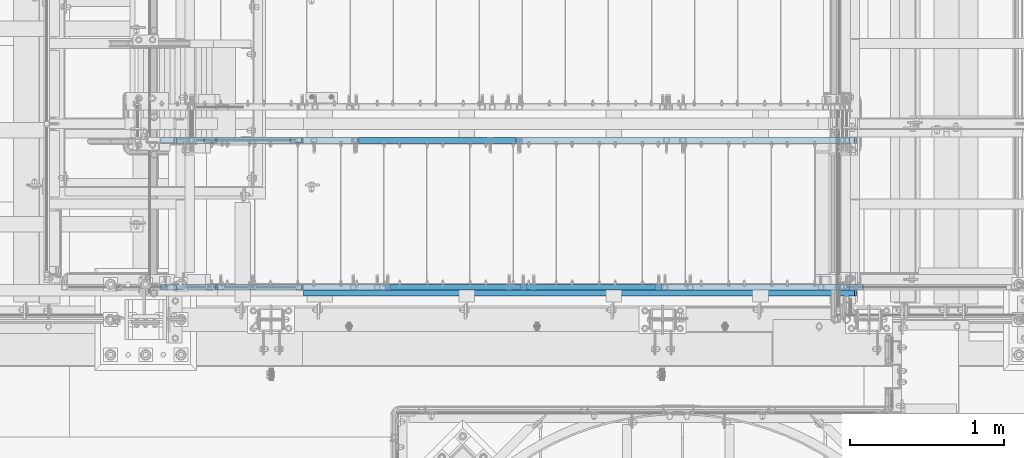
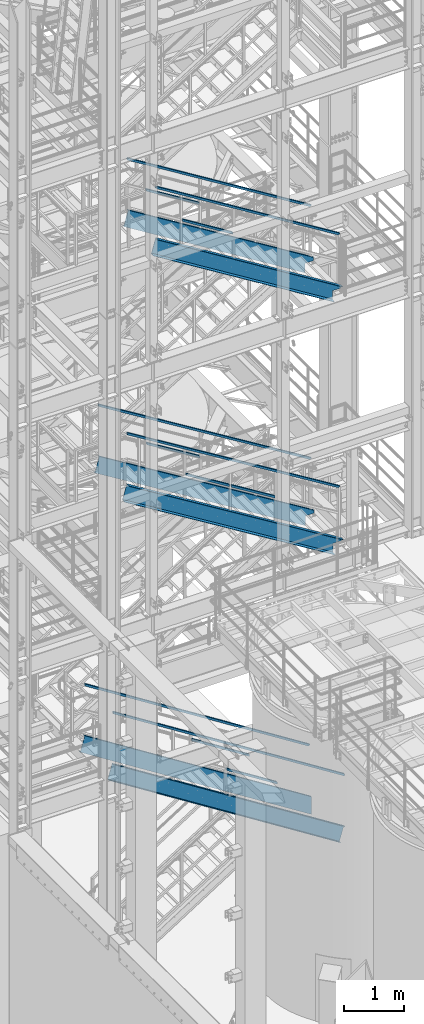
# One storey, part 947 of 1876: 19 members, 9 elements without a shape of their own.
"""IFC2X3 building model written with IfcOpenShell, lengths in millimetres."""

import ifcopenshell
import ifcopenshell.guid

model = None  # the IFC model being written
_history = None  # IfcOwnerHistory: only IFC2X3 demands one
_inside = {}  # id of a spatial element -> (the spatial element, [elements in it])
_under = {}  # id of a project, library or spatial element -> (it, [spatial elements below it])
_declared = {}  # id of a project -> (the project, [libraries it declares])
_typed = {}  # id of a type object -> (the type object, [elements of that type])
_made_of = {}  # id of a material, layer set ... -> (it, [elements and type objects made of it])


def new_model(schema):
    """Start an empty IFC model of exactly this schema.

    Asked for "IFC4X3", IfcOpenShell would pick the latest addendum, in which some entities
    have other attributes; the version numbers below select the first issue.
    IFC2X3 requires an IfcOwnerHistory on every rooted entity: one is made here for all.
    """
    global model, _history
    if schema == "IFC4X3":
        model = ifcopenshell.file(schema_version=(4, 3, 0, 0))
    else:
        model = ifcopenshell.file(schema=schema)
    _inside.clear()
    _under.clear()
    _declared.clear()
    _typed.clear()
    _made_of.clear()
    _history = None
    if model.schema == "IFC2X3":
        org = make("IfcOrganization", Name="unknown")
        user = make(
            "IfcPersonAndOrganization",
            ThePerson=make("IfcPerson", FamilyName="unknown"),
            TheOrganization=org,
        )
        app = make(
            "IfcApplication",
            ApplicationDeveloper=org,
            Version="unknown",
            ApplicationFullName="unknown",
            ApplicationIdentifier="unknown",
        )
        _history = make(
            "IfcOwnerHistory",
            OwningUser=user,
            OwningApplication=app,
            ChangeAction="ADDED",
            CreationDate=0,
        )
    return model


def make(cls, **values):
    """One entity of the class cls with the attributes given. An attribute that is None is left unset."""
    return model.create_entity(
        cls, **{name: value for name, value in values.items() if value is not None}
    )


def rooted(cls, **values):
    """An entity with a GlobalId (a new one), such as an element, a storey or a relation."""
    return make(cls, GlobalId=ifcopenshell.guid.new(), OwnerHistory=_history, **values)


def si_unit(unit_type, name, prefix=None):
    """IfcSIUnit, for example si_unit("LENGTHUNIT", "METRE", prefix="MILLI")."""
    return make("IfcSIUnit", UnitType=unit_type, Prefix=prefix, Name=name)


def assignment(units):
    """IfcUnitAssignment: the units of a project."""
    return None if units is None else make("IfcUnitAssignment", Units=units)


def point(xyz):
    """IfcCartesianPoint."""
    return None if xyz is None else make("IfcCartesianPoint", Coordinates=xyz)


def direction(xyz):
    """IfcDirection."""
    return None if xyz is None else make("IfcDirection", DirectionRatios=xyz)


def frame(location, z_axis=None, x_axis=None):
    """IfcAxis2Placement3D, a coordinate frame: its origin and axes. An axis left out is left unset."""
    return make(
        "IfcAxis2Placement3D",
        Location=point(location),
        Axis=direction(z_axis),
        RefDirection=direction(x_axis),
    )


def origin_with_axes():
    """The frame at (0, 0, 0) with the z axis (0, 0, 1) and the x axis (1, 0, 0) written out."""
    return frame((0.0, 0.0, 0.0), z_axis=(0.0, 0.0, 1.0), x_axis=(1.0, 0.0, 0.0))


def place(relative_to, where):
    """IfcLocalPlacement: puts the frame where relative to a parent placement (None: the world)."""
    return make(
        "IfcLocalPlacement", PlacementRelTo=relative_to, RelativePlacement=where
    )


def context(
    kind, dimensions, precision=None, world=None, true_north=None, identifier=None
):
    """IfcGeometricRepresentationContext, for example the 3D "Model" context."""
    return make(
        "IfcGeometricRepresentationContext",
        ContextIdentifier=identifier,
        ContextType=kind,
        CoordinateSpaceDimension=dimensions,
        Precision=precision,
        WorldCoordinateSystem=world,
        TrueNorth=true_north,
    )


def subcontext(parent, identifier, kind, view, scale=None):
    """IfcGeometricRepresentationSubContext, for example "Body" below "Model"."""
    return make(
        "IfcGeometricRepresentationSubContext",
        ContextIdentifier=identifier,
        ContextType=kind,
        ParentContext=parent,
        TargetScale=scale,
        TargetView=view,
    )


def project(units=None, contexts=None):
    """IfcProject with its units and contexts."""
    return rooted(
        "IfcProject",
        Name="project",
        RepresentationContexts=contexts,
        UnitsInContext=assignment(units),
    )


def spatial(cls, under=None, at=None, **own):
    """A site, building, storey or space (cls), placed at a placement, below another one or the project."""
    s = rooted(cls, ObjectPlacement=at, **own)
    if under is not None:
        _under.setdefault(under.id(), (under, []))[1].append(s)
    return s


def faces_of(points, faces, orient=None, outer=None):
    """IfcFace entities. A face is a list of loops; a loop is a list of indices into points, from 0.

    orient and outer hold one flag for each loop. By default every Orientation is true, the
    first loop of a face is its IfcFaceOuterBound and the others are IfcFaceBound.
    """
    made = []
    for i, loops in enumerate(faces):
        bounds = []
        for j, loop in enumerate(loops):
            is_outer = j == 0 if outer is None else outer[i][j]
            bounds.append(
                make(
                    "IfcFaceOuterBound" if is_outer else "IfcFaceBound",
                    Bound=make("IfcPolyLoop", Polygon=[points[k] for k in loop]),
                    Orientation=True if orient is None else orient[i][j],
                )
            )
        made.append(make("IfcFace", Bounds=bounds))
    return made


def faceted_brep(points, faces, orient=None, outer=None, voids=None):
    """IfcFacetedBrep: a solid bounded by flat faces; with voids (closed shells), ...WithVoids."""
    shared = [point(p) for p in points]
    hull = make("IfcClosedShell", CfsFaces=faces_of(shared, faces, orient, outer))
    if voids is None:
        return make("IfcFacetedBrep", Outer=hull)
    return make(
        "IfcFacetedBrepWithVoids",
        Outer=hull,
        Voids=[
            make(cls, CfsFaces=faces_of(shared, fs, o, b)) for cls, fs, o, b in voids
        ],
    )


def shape(context_of_items, identifier, shape_type, items):
    """IfcShapeRepresentation: the items that make up one representation, for example the "Body"."""
    return make(
        "IfcShapeRepresentation",
        ContextOfItems=context_of_items,
        RepresentationIdentifier=identifier,
        RepresentationType=shape_type,
        Items=items,
    )


def material(Name=None, Category=None):
    """IfcMaterial."""
    return make("IfcMaterial", Name=Name, Category=Category)


def made_of(thing, what):
    """Note that an element or type object is made of a material, layer set ...; save() writes the relation."""
    if what is not None:
        _made_of.setdefault(what.id(), (what, []))[1].append(thing)
    return thing


def type_object(cls, material=None, **own):
    """A type object (cls), such as IfcWallType, which elements share."""
    return made_of(rooted(cls, **own), material)


def element(
    cls,
    number,
    at=None,
    inside=None,
    cuts=None,
    type_object=None,
    material=None,
    context=None,
    identifier="Body",
    shape_type=None,
    held_by="IfcProductDefinitionShape",
    body=None,
    shapes=None,
    **own,
):
    """One element of the class cls, such as IfcWall. Its Tag is "e" and its number.

    at: its placement. inside: the storey or other place that contains it. cuts: it is an
    opening in that element (IfcRelVoidsElement). A single representation is given by context,
    identifier, shape_type and body (its items); several are given by shapes. held_by: the class
    of the entity that holds the representations. save() writes the other relations.
    """
    e = rooted(cls, Tag="e%d" % number, ObjectPlacement=at, **own)
    if body is not None:
        shapes = [shape(context, identifier, shape_type, body)]
    if shapes is not None:
        e.Representation = make(held_by, Representations=shapes)
    if inside is not None:
        _inside.setdefault(inside.id(), (inside, []))[1].append(e)
    if cuts is not None:
        rooted(
            "IfcRelVoidsElement", RelatingBuildingElement=cuts, RelatedOpeningElement=e
        )
    if type_object is not None:
        _typed.setdefault(type_object.id(), (type_object, []))[1].append(e)
    return made_of(e, material)


def aggregate(whole, parts):
    """IfcRelAggregates: a whole, such as a stair, and the parts it consists of."""
    return rooted("IfcRelAggregates", RelatingObject=whole, RelatedObjects=parts)


def save(model, path):
    """Write the relations noted so far, then the file.

    IfcRelAggregates (storeys below a building ...), IfcRelContainedInSpatialStructure (elements
    in a storey), IfcRelDefinesByType, IfcRelAssociatesMaterial and IfcRelDeclares: one each for
    every whole, place, type object, material and project.
    """
    for whole, parts in _under.values():
        aggregate(whole, parts)
    for where, things in _inside.values():
        rooted(
            "IfcRelContainedInSpatialStructure",
            RelatedElements=things,
            RelatingStructure=where,
        )
    for kind, things in _typed.values():
        rooted("IfcRelDefinesByType", RelatedObjects=things, RelatingType=kind)
    for what, things in _made_of.values():
        rooted("IfcRelAssociatesMaterial", RelatedObjects=things, RelatingMaterial=what)
    for by, libraries in _declared.values():
        rooted("IfcRelDeclares", RelatingContext=by, RelatedDefinitions=libraries)
    model.write(path)


model = new_model("IFC2X3")

# Units and contexts
model_context = context("Model", 3, precision=1e-05, world=origin_with_axes())
body_context = subcontext(model_context, "Body", "Model", "MODEL_VIEW")
ifc_project = project(units=[si_unit("LENGTHUNIT", "METRE", prefix="MILLI"), si_unit("AREAUNIT", "SQUARE_METRE"), si_unit("VOLUMEUNIT", "CUBIC_METRE"), si_unit("MASSUNIT", "GRAM", prefix="KILO"), si_unit("TIMEUNIT", "SECOND"), si_unit("PLANEANGLEUNIT", "RADIAN"), si_unit("SOLIDANGLEUNIT", "STERADIAN"), si_unit("THERMODYNAMICTEMPERATUREUNIT", "DEGREE_CELSIUS"), si_unit("LUMINOUSINTENSITYUNIT", "LUMEN")], contexts=[model_context])

# Site, building, storey
site_placement = place(None, origin_with_axes())
site = spatial("IfcSite", under=ifc_project, at=site_placement, CompositionType="ELEMENT")
building_placement = place(site_placement, origin_with_axes())
building = spatial("IfcBuilding", under=site, at=building_placement, Name="Undefined", CompositionType="ELEMENT")
storey_placement = place(building_placement, origin_with_axes())
storey = spatial("IfcBuildingStorey", under=building, at=storey_placement, Name="Undefined", CompositionType="ELEMENT", Elevation=0.0)

# Assembly, members
assembly_1_placement = place(storey_placement, origin_with_axes())
assembly_1 = element("IfcElementAssembly", 1, at=assembly_1_placement, inside=storey, Name="RAIL", AssemblyPlace="NOTDEFINED", PredefinedType="RIGID_FRAME")
ifc_material_1 = material()
member_type_1 = type_object("IfcMemberType", Name="HSS1-1/2X1-1/2X1/8", PredefinedType="NOTDEFINED")
member_1_placement = place(assembly_1_placement, frame((5105.40000153797, -5949.95000114554, 3643.37719494861), z_axis=(0.535697420207059, 0.0, 0.844410015326383), x_axis=(-0.844410015326383, 0.0, 0.535697420207059)))
member_1 = element("IfcMember", 2, at=member_1_placement, type_object=member_type_1, material=ifc_material_1, Name="RAIL", ObjectType="HSS1-1/2X1-1/2X1/8", context=body_context, shape_type="Brep", body=[
    faceted_brep([(1343.13309186325, -19.0499992349996, 19.0499992346431), (1318.96228559638, -19.0499992349996, -19.0499992353589), (1318.96228559638, 19.0499992349996, -19.0499992353589), (1343.13309186325, 19.0499992349996, 19.0499992346431), (1341.11885795724, -15.8749992829999, 15.8749992826424), (1341.11885795724, 15.8749992829999, 15.8749992826424), (1320.97651950239, 15.8749992829999, -15.8749992833582), (1320.97651950239, -15.8749992829999, -15.8749992833582), (10.4747262991696, 19.0499992349996, -19.0499992349991), (34.6455325374254, 19.0499992349996, 19.049999235012), (34.6455325374254, -19.0499992349996, 19.049999235012), (10.4747262991696, -19.0499992349996, -19.0499992349991), (32.6312986338025, 15.8749992829999, 15.8749992830109), (32.6312986338025, -15.8749992829999, 15.8749992830109), (12.4889602027924, -15.8749992829999, -15.8749992829981), (12.4889602027924, 15.8749992829999, -15.8749992829981)], [[[0, 1, 2, 3], [4, 5, 6, 7]], [[3, 2, 8, 9]], [[0, 3, 9, 10]], [[1, 0, 10, 11]], [[2, 1, 11, 8]], [[11, 10, 9, 8], [12, 13, 14, 15]], [[4, 7, 14, 13]], [[7, 6, 15, 14]], [[6, 5, 12, 15]], [[5, 4, 13, 12]]]),
])
member_2_placement = place(assembly_1_placement, frame((1920.01408886274, -5949.95000114554, 6197.60000000056), z_axis=(-0.535697420207059, 0.0, -0.844410015326383), x_axis=(0.844410015326383, 0.0, -0.535697420207059)))
member_2 = element("IfcMember", 3, at=member_2_placement, type_object=member_type_1, material=ifc_material_1, Name="RAIL", ObjectType="HSS1-1/2X1-1/2X1/8", context=body_context, shape_type="Brep", body=[
    faceted_brep([(-4.61079482035893, 15.8749992829999, -15.8749992830034), (-4.61079482035893, -15.8749992829999, -15.8749992830034), (5134.65808738734, -15.8749992829999, -15.8749992837593), (5134.65808738734, 15.8749992829999, -15.8749992837593), (4.61079481841625, -15.8749992829999, 15.8749992830026), (5117.20021032863, -15.8749992829999, 15.8749992822459), (4.61079481841625, 15.8749992829999, 15.8749992830026), (5117.20021032863, 15.8749992829999, 15.8749992822459), (-5.53295381194494, 19.0499992349996, -19.0499992350046), (5.53295381000225, 19.0499992349996, 19.0499992350038), (5115.4544225703, 19.0499992349996, 19.0499992342466), (5136.40387514567, 19.0499992349996, -19.0499992357609), (5.53295381000225, -19.0499992349996, 19.0499992350038), (5115.4544225703, -19.0499992349996, 19.0499992342466), (-5.53295381194494, -19.0499992349996, -19.0499992350046), (5136.40387514567, -19.0499992349996, -19.0499992357609)], [[[0, 1, 2, 3]], [[1, 4, 5, 2]], [[4, 6, 7, 5]], [[6, 0, 3, 7]], [[8, 9, 10, 11]], [[9, 12, 13, 10]], [[12, 14, 15, 13]], [[14, 8, 11, 15]], [[13, 15, 11, 10], [5, 7, 3, 2]], [[14, 12, 9, 8], [6, 4, 1, 0]]]),
])
aggregate(assembly_1, [member_1, member_2])

assembly_2_placement = place(storey_placement, origin_with_axes())
assembly_2 = element("IfcElementAssembly", 4, at=assembly_2_placement, inside=storey, Name="RAIL", AssemblyPlace="NOTDEFINED", PredefinedType="RIGID_FRAME")
member_3_placement = place(assembly_2_placement, frame((5095.87500293196, -6902.45000114554, 3658.94489587197), z_axis=(0.535697420207059, 0.0, 0.844410015326383), x_axis=(-0.844410015326383, 0.0, 0.535697420207059)))
member_3 = element("IfcMember", 5, at=member_3_placement, type_object=member_type_1, material=ifc_material_1, Name="RAIL", ObjectType="HSS1-1/2X1-1/2X1/8", context=body_context, shape_type="Brep", body=[
    faceted_brep([(1187.09219031264, -19.0499992349996, 19.0499992346859), (1162.92138404577, -19.0499992349996, -19.0499992353161), (1162.92138404577, 19.0499992349996, -19.0499992353161), (1187.09219031264, 19.0499992349996, 19.0499992346859), (1185.07795640663, -15.8749992829999, 15.8749992826852), (1185.07795640663, 15.8749992829999, 15.8749992826852), (1164.93561795178, 15.8749992829999, -15.8749992833154), (1164.93561795178, -15.8749992829999, -15.8749992833154), (10.4747262991696, 19.0499992349996, -19.0499992349991), (34.6455325374254, 19.0499992349996, 19.049999235012), (34.6455325374254, -19.0499992349996, 19.049999235012), (10.4747262991696, -19.0499992349996, -19.0499992349991), (32.6312986338025, 15.8749992829999, 15.8749992830109), (32.6312986338025, -15.8749992829999, 15.8749992830109), (12.4889602027924, -15.8749992829999, -15.8749992829981), (12.4889602027924, 15.8749992829999, -15.8749992829981)], [[[0, 1, 2, 3], [4, 5, 6, 7]], [[3, 2, 8, 9]], [[0, 3, 9, 10]], [[1, 0, 10, 11]], [[2, 1, 11, 8]], [[11, 10, 9, 8], [12, 13, 14, 15]], [[4, 7, 14, 13]], [[7, 6, 15, 14]], [[6, 5, 12, 15]], [[5, 4, 13, 12]]]),
])
member_4_placement = place(assembly_2_placement, frame((1920.01408941576, -6902.45000114554, 6207.12499999989), z_axis=(-0.535697420207059, 0.0, -0.844410015326383), x_axis=(0.844410015326383, 0.0, -0.535697420207059)))
member_4 = element("IfcMember", 6, at=member_4_placement, type_object=member_type_1, material=ifc_material_1, Name="RAIL", ObjectType="HSS1-1/2X1-1/2X1/8", context=body_context, shape_type="Brep", body=[
    faceted_brep([(-4.61079482035893, 15.8749992829999, -15.8749992830034), (-4.61079482035893, -15.8749992829999, -15.8749992830034), (5271.71922317795, -15.8749992829999, -15.8749992837784), (5271.71922317795, 15.8749992829999, -15.8749992837784), (4.61079481841625, -15.8749992829999, 15.8749992830026), (5280.94081282555, -15.8749992829999, 15.8749992822231), (4.61079481841625, 15.8749992829999, 15.8749992830026), (5280.94081282555, 15.8749992829999, 15.8749992822231), (-5.53295381194494, 19.0499992349996, -19.0499992350046), (5.53295381000225, 19.0499992349996, 19.0499992350038), (5281.86297181802, 19.0499992349996, 19.0499992342229), (5270.79706418548, 19.0499992349996, -19.0499992357791), (5.53295381000225, -19.0499992349996, 19.0499992350038), (5281.86297181802, -19.0499992349996, 19.0499992342229), (-5.53295381194494, -19.0499992349996, -19.0499992350046), (5270.79706418548, -19.0499992349996, -19.0499992357791)], [[[0, 1, 2, 3]], [[1, 4, 5, 2]], [[4, 6, 7, 5]], [[6, 0, 3, 7]], [[8, 9, 10, 11]], [[9, 12, 13, 10]], [[12, 14, 15, 13]], [[14, 8, 11, 15]], [[13, 15, 11, 10], [5, 7, 3, 2]], [[14, 12, 9, 8], [6, 4, 1, 0]]]),
])
aggregate(assembly_2, [member_3, member_4])

assembly_3_placement = place(storey_placement, origin_with_axes())
assembly_3 = element("IfcElementAssembly", 7, at=assembly_3_placement, inside=storey, Name="RAIL", AssemblyPlace="NOTDEFINED", PredefinedType="RIGID_FRAME")
member_5_placement = place(assembly_3_placement, frame((4176.18333383744, -6902.45000114554, 10049.1836660495), z_axis=(0.523955482879573, 0.0, 0.851745649804232), x_axis=(-0.851745649804232, 0.0, 0.523955482879573)))
member_5 = element("IfcMember", 8, at=member_5_placement, type_object=member_type_1, material=ifc_material_1, Name="RAIL", ObjectType="HSS1-1/2X1-1/2X1/8", context=body_context, shape_type="Brep", body=[
    faceted_brep([(1020.66622709623, -19.0499992349996, 19.0499992356781), (997.228827561887, -19.0499992349996, -19.0499992343539), (997.228827561887, 19.0499992349996, -19.0499992343539), (1020.66622709623, 19.0499992349996, 19.0499992356781), (1018.71311041946, -15.8749992829999, 15.8749992836765), (1018.71311041946, 15.8749992829999, 15.8749992836765), (999.181944238654, 15.8749992829999, -15.8749992823523), (999.181944238654, -15.8749992829999, -15.8749992823523), (10.6471616099025, 19.0499992349996, -19.0499992350033), (34.0845307397099, 19.0499992349996, 19.0499992350287), (34.0845307397099, -19.0499992349996, 19.0499992350287), (10.6471616099025, -19.0499992349996, -19.0499992350033), (32.1314140629433, 15.8749992829999, 15.8749992830271), (32.1314140629433, -15.8749992829999, 15.8749992830271), (12.6002676416374, -15.8749992829999, -15.8749992830035), (12.6002676416374, 15.8749992829999, -15.8749992830035)], [[[0, 1, 2, 3], [4, 5, 6, 7]], [[3, 2, 8, 9]], [[0, 3, 9, 10]], [[1, 0, 10, 11]], [[2, 1, 11, 8]], [[11, 10, 9, 8], [12, 13, 14, 15]], [[4, 7, 14, 13]], [[7, 6, 15, 14]], [[6, 5, 12, 15]], [[5, 4, 13, 12]]]),
])
member_6_placement = place(assembly_3_placement, frame((5054.60000035646, -6902.45000114554, 9508.82137739988), z_axis=(0.523955482879573, 0.0, 0.851745649804232), x_axis=(-0.851745649804232, 0.0, 0.523955482879573)))
member_6 = element("IfcMember", 9, at=member_6_placement, type_object=member_type_1, material=ifc_material_1, Name="RAIL", ObjectType="HSS1-1/2X1-1/2X1/8", context=body_context, shape_type="Brep", body=[
    faceted_brep([(1020.66622709623, -19.0499992349996, 19.0499992356781), (997.228827561887, -19.0499992349996, -19.0499992343539), (997.228827561887, 19.0499992349996, -19.0499992343539), (1020.66622709623, 19.0499992349996, 19.0499992356781), (1018.71311041946, -15.8749992829999, 15.8749992836765), (1018.71311041946, 15.8749992829999, 15.8749992836765), (999.181944238654, 15.8749992829999, -15.8749992823523), (999.181944238654, -15.8749992829999, -15.8749992823523), (10.6471616099025, 19.0499992349996, -19.0499992350033), (34.0845307397099, 19.0499992349996, 19.0499992350287), (34.0845307397099, -19.0499992349996, 19.0499992350287), (10.6471616099025, -19.0499992349996, -19.0499992350033), (32.1314140629433, 15.8749992829999, 15.8749992830271), (32.1314140629433, -15.8749992829999, 15.8749992830271), (12.6002676416374, -15.8749992829999, -15.8749992830035), (12.6002676416374, 15.8749992829999, -15.8749992830035)], [[[0, 1, 2, 3], [4, 5, 6, 7]], [[3, 2, 8, 9]], [[0, 3, 9, 10]], [[1, 0, 10, 11]], [[2, 1, 11, 8]], [[11, 10, 9, 8], [12, 13, 14, 15]], [[4, 7, 14, 13]], [[7, 6, 15, 14]], [[6, 5, 12, 15]], [[5, 4, 13, 12]]]),
])
member_7_placement = place(assembly_3_placement, frame((2184.42256528301, -6902.45000114554, 11807.8249989611), z_axis=(-0.523955482879573, 0.0, -0.851745649804232), x_axis=(0.851745649804232, 0.0, -0.523955482879573)))
member_7 = element("IfcMember", 10, at=member_7_placement, type_object=member_type_1, material=ifc_material_1, Name="RAIL", ObjectType="HSS1-1/2X1-1/2X1/8", context=body_context, shape_type="Brep", body=[
    faceted_brep([(-4.49184492785935, 15.8749992829999, -15.8749992829999), (-4.49184492785935, -15.8749992829999, -15.8749992829999), (4810.04469161304, -15.8749992829999, -15.8749992798548), (4810.04469161304, 15.8749992829999, -15.8749992798548), (4.49184492431232, -15.8749992829999, 15.8749992829999), (4792.29947303204, -15.8749992829999, 15.8749992861467), (4.49184492431232, 15.8749992829999, 15.8749992829999), (4792.29947303204, 15.8749992829999, 15.8749992861467), (-5.39021394007068, 19.0499992349996, -19.0499992349996), (5.39021393652274, 19.0499992349996, 19.0499992349996), (4790.52495112061, 19.0499992349996, 19.0499992381465), (4811.81921352446, 19.0499992349996, -19.0499992318546), (5.39021393652274, -19.0499992349996, 19.0499992349996), (4790.52495112061, -19.0499992349996, 19.0499992381465), (-5.39021394007068, -19.0499992349996, -19.0499992349996), (4811.81921352446, -19.0499992349996, -19.0499992318546)], [[[0, 1, 2, 3]], [[1, 4, 5, 2]], [[4, 6, 7, 5]], [[6, 0, 3, 7]], [[8, 9, 10, 11]], [[9, 12, 13, 10]], [[12, 14, 15, 13]], [[14, 8, 11, 15]], [[13, 15, 11, 10], [5, 7, 3, 2]], [[14, 12, 9, 8], [6, 4, 1, 0]]]),
])
aggregate(assembly_3, [member_5, member_6, member_7])

assembly_4_placement = place(storey_placement, origin_with_axes())
assembly_4 = element("IfcElementAssembly", 11, at=assembly_4_placement, inside=storey, Name="RAIL", AssemblyPlace="NOTDEFINED", PredefinedType="RIGID_FRAME")
member_8_placement = place(assembly_4_placement, frame((4152.90000057839, -5949.95000114554, 10063.5065218502), z_axis=(0.523955482879573, 0.0, 0.851745649804232), x_axis=(-0.851745649804232, 0.0, 0.523955482879573)))
member_8 = element("IfcMember", 12, at=member_8_placement, type_object=member_type_1, material=ifc_material_1, Name="RAIL", ObjectType="HSS1-1/2X1-1/2X1/8", context=body_context, shape_type="Brep", body=[
    faceted_brep([(10.6471616099025, -19.0499992349996, -19.0499992350033), (34.0845307397099, -19.0499992349996, 19.0499992350287), (34.0845307397099, 19.0499992349996, 19.0499992350287), (10.6471616099025, 19.0499992349996, -19.0499992350033), (32.1314140629433, 15.8749992829999, 15.8749992830271), (32.1314140629433, -15.8749992829999, 15.8749992830271), (12.6002676416374, -15.8749992829999, -15.8749992830035), (12.6002676416374, 15.8749992829999, -15.8749992830035), (1210.94677659227, 19.0499992349996, -19.0499992339264), (1210.94677659227, -19.0499992349996, -19.0499992339264), (1234.38417612661, -19.0499992349996, 19.049999236111), (1234.38417612661, 19.0499992349996, 19.049999236111), (1232.43105944984, -15.8749992829999, 15.8749992841076), (1232.43105944984, 15.8749992829999, 15.8749992841076), (1212.89989326904, 15.8749992829999, -15.874999281923), (1212.89989326904, -15.8749992829999, -15.874999281923)], [[[0, 1, 2, 3], [4, 5, 6, 7]], [[8, 9, 0, 3]], [[9, 10, 1, 0]], [[10, 11, 2, 1]], [[11, 8, 3, 2]], [[10, 9, 8, 11], [12, 13, 14, 15]], [[13, 12, 5, 4]], [[14, 13, 4, 7]], [[15, 14, 7, 6]], [[12, 15, 6, 5]]]),
])
member_9_placement = place(assembly_4_placement, frame((2184.42256528348, -5949.95000114554, 11807.8249989611), z_axis=(-0.523955482879573, 0.0, -0.851745649804232), x_axis=(0.851745649804232, 0.0, -0.523955482879573)))
member_9 = element("IfcMember", 13, at=member_9_placement, type_object=member_type_1, material=ifc_material_1, Name="RAIL", ObjectType="HSS1-1/2X1-1/2X1/8", context=body_context, shape_type="Brep", body=[
    faceted_brep([(-4.49184492785935, 15.8749992829999, -15.8749992829999), (-4.49184492785935, -15.8749992829999, -15.8749992829999), (4810.04469161304, -15.8749992829999, -15.8749992798548), (4810.04469161304, 15.8749992829999, -15.8749992798548), (4.49184492431232, -15.8749992829999, 15.8749992829999), (4792.29947303204, -15.8749992829999, 15.8749992861467), (4.49184492431232, 15.8749992829999, 15.8749992829999), (4792.29947303204, 15.8749992829999, 15.8749992861467), (-5.39021394007068, 19.0499992349996, -19.0499992349996), (5.39021393652274, 19.0499992349996, 19.0499992349996), (4790.52495112061, 19.0499992349996, 19.0499992381465), (4811.81921352446, 19.0499992349996, -19.0499992318546), (5.39021393652274, -19.0499992349996, 19.0499992349996), (4790.52495112061, -19.0499992349996, 19.0499992381465), (-5.39021394007068, -19.0499992349996, -19.0499992349996), (4811.81921352446, -19.0499992349996, -19.0499992318546)], [[[0, 1, 2, 3]], [[1, 4, 5, 2]], [[4, 6, 7, 5]], [[6, 0, 3, 7]], [[8, 9, 10, 11]], [[9, 12, 13, 10]], [[12, 14, 15, 13]], [[14, 8, 11, 15]], [[13, 15, 11, 10], [5, 7, 3, 2]], [[14, 12, 9, 8], [6, 4, 1, 0]]]),
])
aggregate(assembly_4, [member_8, member_9])

assembly_5_placement = place(storey_placement, origin_with_axes())
assembly_5 = element("IfcElementAssembly", 14, at=assembly_5_placement, inside=storey, Name="RAIL", AssemblyPlace="NOTDEFINED", PredefinedType="RIGID_FRAME")
member_10_placement = place(assembly_5_placement, frame((4244.34000046683, -6902.45000114053, 15172.7772125448), z_axis=(0.526655381891443, 0.0, 0.850078883824777), x_axis=(-0.850078883824777, 0.0, 0.526655381891443)))
member_10 = element("IfcMember", 15, at=member_10_placement, type_object=member_type_1, material=ifc_material_1, Name="RAIL", ObjectType="HSS1-1/2X1-1/2X1/8", context=body_context, shape_type="Brep", body=[
    faceted_brep([(34.2118657176925, -19.0499992349996, 19.0499992349851), (34.2118657176925, 19.0499992349996, 19.0499992349851), (10.6075042565662, 19.0499992349996, -19.049999234996), (10.6075042565662, -19.0499992349996, -19.049999234996), (32.2448355466786, -15.8749992829999, 15.8749992829853), (12.5745344275801, -15.8749992829999, -15.8749992829962), (12.5745344275801, 15.8749992829999, -15.8749992829962), (32.2448355466786, 15.8749992829999, 15.8749992829853), (1159.47716244294, 19.0499992349996, -19.0499992352943), (1159.47716244294, -19.0499992349996, -19.0499992352943), (1183.08152390407, -19.0499992349996, 19.0499992346868), (1183.08152390407, 19.0499992349996, 19.0499992346868), (1181.11449373305, -15.8749992829999, 15.874999282687), (1181.11449373305, 15.8749992829999, 15.874999282687), (1161.44419261395, 15.8749992829999, -15.8749992832963), (1161.44419261395, -15.8749992829999, -15.8749992832963)], [[[0, 1, 2, 3], [4, 5, 6, 7]], [[8, 9, 3, 2]], [[9, 10, 0, 3]], [[10, 11, 1, 0]], [[11, 8, 2, 1]], [[10, 9, 8, 11], [12, 13, 14, 15]], [[13, 12, 4, 7]], [[14, 13, 7, 6]], [[15, 14, 6, 5]], [[12, 15, 5, 4]]]),
])
member_11_placement = place(assembly_5_placement, frame((2743.20017002666, -6902.45000114671, 16636.1768506258), z_axis=(-0.52665039020876, 0.0, -0.850081976336965), x_axis=(0.850081976336965, 0.0, -0.52665039020876)))
member_11 = element("IfcMember", 16, at=member_11_placement, type_object=member_type_1, material=ifc_material_1, Name="RAIL", ObjectType="HSS1-1/2X1-1/2X1/8", context=body_context, shape_type="Brep", body=[
    faceted_brep([(-4.5191335683312, 15.8749992829999, -15.8749992829871), (-4.5191335683312, -15.8749992829999, -15.8749992829871), (4162.02662234796, -15.8749992829999, -15.8749992811372), (4162.02662234796, 15.8749992829999, -15.8749992811372), (4.51913358162346, -15.8749992829999, 15.8749992829853), (4144.34758089372, -15.8749992829999, 15.8749992848261), (4.51913358162346, 15.8749992829999, 15.8749992829853), (4144.34758089372, 15.8749992829999, 15.8749992848261), (-5.42296031048409, 19.0499992349996, -19.0499992349833), (5.42296032377726, 19.0499992349996, 19.0499992349851), (4142.57967669517, 19.0499992349996, 19.0499992368223), (4163.79452654651, 19.0499992349996, -19.0499992331333), (5.42296032377726, -19.0499992349996, 19.0499992349851), (4142.57967669517, -19.0499992349996, 19.0499992368223), (-5.42296031048409, -19.0499992349996, -19.0499992349833), (4163.79452654651, -19.0499992349996, -19.0499992331333)], [[[0, 1, 2, 3]], [[1, 4, 5, 2]], [[4, 6, 7, 5]], [[6, 0, 3, 7]], [[8, 9, 10, 11]], [[9, 12, 13, 10]], [[12, 14, 15, 13]], [[14, 8, 11, 15]], [[13, 15, 11, 10], [5, 7, 3, 2]], [[14, 12, 9, 8], [6, 4, 1, 0]]]),
])
aggregate(assembly_5, [member_10, member_11])

assembly_6_placement = place(storey_placement, origin_with_axes())
assembly_6 = element("IfcElementAssembly", 17, at=assembly_6_placement, inside=storey, Name="RAIL", AssemblyPlace="NOTDEFINED", PredefinedType="RIGID_FRAME")
member_12_placement = place(assembly_6_placement, frame((4146.55000058558, -5949.95000114554, 15233.3609451088), z_axis=(0.526653728932879, 0.0, 0.85007990789166), x_axis=(-0.85007990789166, 0.0, 0.526653728932879)))
member_12 = element("IfcMember", 18, at=member_12_placement, type_object=member_type_1, material=ifc_material_1, Name="RAIL", ObjectType="HSS1-1/2X1-1/2X1/8", context=body_context, shape_type="Brep", body=[
    faceted_brep([(34.2117874649475, -19.0499992349996, 19.0499992350178), (34.2117874649475, 19.0499992349996, 19.0499992350178), (10.6075042565662, 19.0499992349996, -19.049999234996), (10.6075778003737, -19.0499992349996, -19.0499992350105), (32.244765837263, -15.8749992829999, 15.8749992830162), (12.5745344275801, -15.8749992829999, -15.8749992829962), (12.5745344275801, 15.8749992829999, -15.8749992829962), (32.244765837263, 15.8749992829999, 15.8749992830162), (1216.99392504088, 19.0499992349996, -19.0499992345503), (1216.99392504088, -19.0499992349996, -19.0499992345503), (1240.5981839821, -19.0499992349996, 19.0499992354653), (1240.5981839821, 19.0499992349996, 19.0499992354653), (1238.63116235442, -15.8749992829999, 15.8749992834637), (1238.63116235442, 15.8749992829999, 15.8749992834637), (1218.96094666857, 15.8749992829999, -15.8749992825469), (1218.96094666857, -15.8749992829999, -15.8749992825469)], [[[0, 1, 2, 3], [4, 5, 6, 7]], [[8, 9, 3, 2]], [[9, 10, 0, 3]], [[10, 11, 1, 0]], [[11, 8, 2, 1]], [[10, 9, 8, 11], [12, 13, 14, 15]], [[13, 12, 4, 7]], [[14, 13, 7, 6]], [[15, 14, 6, 5]], [[12, 15, 5, 4]]]),
])
member_13_placement = place(assembly_6_placement, frame((2743.20016971513, -5949.95000114554, 16636.176850817), z_axis=(-0.52665039020876, 0.0, -0.850081976336965), x_axis=(0.850081976336965, 0.0, -0.52665039020876)))
member_13 = element("IfcMember", 19, at=member_13_placement, type_object=member_type_1, material=ifc_material_1, Name="RAIL", ObjectType="HSS1-1/2X1-1/2X1/8", context=body_context, shape_type="Brep", body=[
    faceted_brep([(-4.5191335683312, 15.8749992829999, -15.8749992829871), (-4.5191335683312, -15.8749992829999, -15.8749992829871), (4162.02662234796, -15.8749992829999, -15.8749992811372), (4162.02662234796, 15.8749992829999, -15.8749992811372), (4.51913358162346, -15.8749992829999, 15.8749992829853), (4144.34758089372, -15.8749992829999, 15.8749992848261), (4.51913358162346, 15.8749992829999, 15.8749992829853), (4144.34758089372, 15.8749992829999, 15.8749992848261), (-5.42296031048409, 19.0499992349996, -19.0499992349833), (5.42296032377726, 19.0499992349996, 19.0499992349851), (4142.57967669517, 19.0499992349996, 19.0499992368223), (4163.79452654651, 19.0499992349996, -19.0499992331333), (5.42296032377726, -19.0499992349996, 19.0499992349851), (4142.57967669517, -19.0499992349996, 19.0499992368223), (-5.42296031048409, -19.0499992349996, -19.0499992349833), (4163.79452654651, -19.0499992349996, -19.0499992331333)], [[[0, 1, 2, 3]], [[1, 4, 5, 2]], [[4, 6, 7, 5]], [[6, 0, 3, 7]], [[8, 9, 10, 11]], [[9, 12, 13, 10]], [[12, 14, 15, 13]], [[14, 8, 11, 15]], [[13, 15, 11, 10], [5, 7, 3, 2]], [[14, 12, 9, 8], [6, 4, 1, 0]]]),
])
aggregate(assembly_6, [member_12, member_13])

# Assembly, member
assembly_7_placement = place(storey_placement, origin_with_axes())
assembly_7 = element("IfcElementAssembly", 20, at=assembly_7_placement, inside=storey, Name="STRINGER", AssemblyPlace="NOTDEFINED", PredefinedType="RIGID_FRAME")
ifc_material_2 = material(Name="STEEL/A36")
member_type_2 = type_object("IfcMemberType", Name="C12X20.7", PredefinedType="NOTDEFINED")
member_14_placement = place(assembly_7_placement, frame((2670.1689537015, -6921.50000115429, 15465.2243413966), z_axis=(0.5266503718289, 0.0, 0.850081987723821), x_axis=(0.850081976336965, 0.0, -0.52665039020876)))
member_14 = element("IfcMember", 21, at=member_14_placement, type_object=member_type_2, material=ifc_material_2, Name="STRINGER", ObjectType="C12X20.7", context=body_context, shape_type="Brep", body=[
    faceted_brep([(4199.11509400975, -38.1000000000004, -152.399999998766), (4199.11509400975, 38.1000000000004, -152.399999998766), (4098.1336021823, 38.1000000000004, 10.5972920997574), (4098.1336021823, 30.1625000000004, 10.5972920997574), (4188.13390382703, 30.1625000000004, -134.674927498767), (4195.17951349896, -38.1000000000004, -146.047459998768), (4238.48215781681, 30.1625000000004, 97.5472428710582), (4238.48215781681, 38.1000000000004, 97.54724287106), (0.0, -38.1000000000004, 152.4), (1.80833394220826, -38.1000000000004, 146.04745999982), (4208.4348839222, -38.1000000000004, 146.047460001239), (4204.49930341141, -38.1000000000004, 152.400000001238), (0.0, 38.1000000000004, 152.4), (4204.49930341141, 38.1000000000004, 152.400000001238), (86.7653265610461, -38.1000000000004, -152.399999999901), (84.9569925450996, -38.1000000000004, -146.047459999907), (81.7196516755866, 30.1625000000004, -134.674927499917), (5.04567481172126, 30.1625000000004, 134.674927499829), (86.7653265610461, 38.1000000000004, -152.399999999901), (4215.48049359412, 30.1625000000004, 134.674927501241)], [[[0, 1, 2, 3, 4, 5]], [[6, 3, 2, 7]], [[8, 9, 10, 11]], [[12, 8, 11, 13]], [[14, 15, 16, 17, 9, 8, 12, 18]], [[9, 17, 19, 10]], [[13, 11, 10, 19, 6, 7]], [[1, 18, 12, 13, 7, 2]], [[14, 18, 1, 0]], [[15, 14, 0, 5]], [[16, 15, 5, 4]], [[19, 17, 16, 4, 3, 6]]]),
])

assembly_8_placement = place(storey_placement, origin_with_axes())
assembly_8 = element("IfcElementAssembly", 22, at=assembly_8_placement, inside=storey, Name="STRINGER", AssemblyPlace="NOTDEFINED", PredefinedType="RIGID_FRAME")
member_15_placement = place(assembly_8_placement, frame((2111.73645362472, -6921.50000113451, 10636.6187697163), z_axis=(0.523953411146184, 0.0, 0.851746924237639), x_axis=(0.851746924237639, 0.0, -0.523953411146184)))
member_15 = element("IfcMember", 23, at=member_15_placement, type_object=member_type_2, material=ifc_material_2, Name="STRINGER", ObjectType="C12X20.7", context=body_context, shape_type="Brep", body=[
    faceted_brep([(4860.96741339624, -38.1000000000004, -152.400000000067), (4860.96741339624, 38.1000000000004, -152.400000000067), (4756.25117485692, 38.1000000000004, 17.828368011822), (4756.25117485692, 30.1625000000004, 17.828368011822), (4850.06380818803, 30.1625000000004, -134.674927500066), (4857.05963878887, -38.1000000000004, -146.047460000067), (4896.87459464781, 30.1625000000004, 104.333077790994), (4896.87459464781, 38.1000000000004, 104.333077790994), (0.0, -38.1000000000004, 152.4), (1.79745670970442, -38.1000000000004, 146.047460000024), (4871.21392921975, -38.1000000000004, 146.047459999976), (4867.30615461238, -38.1000000000004, 152.399999999978), (0.0, 38.1000000000004, 152.4), (4867.30615461238, 38.1000000000004, 152.399999999978), (86.2434264438216, -38.1000000000004, -152.400000000001), (84.4459696969134, -38.1000000000004, -146.047460000002), (81.2281016832421, 30.1625000000004, -134.674927499999), (5.01532472337567, 30.1625000000004, 134.674927500021), (86.2434264438216, 38.1000000000004, -152.400000000001), (4878.20975982058, 30.1625000000004, 134.674927499975)], [[[0, 1, 2, 3, 4, 5]], [[6, 3, 2, 7]], [[8, 9, 10, 11]], [[12, 8, 11, 13]], [[14, 15, 16, 17, 9, 8, 12, 18]], [[9, 17, 19, 10]], [[13, 11, 10, 19, 6, 7]], [[1, 18, 12, 13, 7, 2]], [[14, 18, 1, 0]], [[15, 14, 0, 5]], [[16, 15, 5, 4]], [[19, 17, 16, 4, 3, 6]]]),
])

# Member
member_type_3 = type_object("IfcMemberType", Name="MC12X10.6", PredefinedType="NOTDEFINED")
member_16_placement = place(assembly_7_placement, frame((6302.36878899242, -5949.95000114575, 13214.972489542), z_axis=(0.5266503718289, 0.0, 0.850081987723821), x_axis=(-0.850081987723821, 0.0, 0.5266503718289)))
member_16 = element("IfcMember", 24, at=member_16_placement, type_object=member_type_3, material=ifc_material_2, Name="STRINGER", ObjectType="MC12X10.6", context=body_context, shape_type="Brep", body=[
    faceted_brep([(174.630028097391, 14.2875000000004, 10.5972942280459), (174.630028097391, 19.0500000000002, 10.5972942280459), (73.6485349504965, 19.0500000000002, -152.399999999987), (73.6485349504965, -19.0500000000002, -152.399999999987), (78.3311833731195, -19.0500000000002, -144.841594999989), (78.7421887448354, 14.2875000000004, -144.178178749989), (34.2814724634427, 14.2875000000004, 97.5472449989975), (34.2814724634427, 19.0500000000002, 97.5472449989975), (68.264325549746, 19.0500000000002, 152.399999999945), (68.264325549746, -19.0500000000002, 152.399999999945), (4272.76363363499, -19.0500000000002, 152.399999998708), (4272.76363363499, 19.0500000000002, 152.399999998708), (63.5816771271238, -19.0500000000002, 144.841594999945), (4270.61203421188, -19.0500000000002, 144.84159499871), (63.170671755408, 14.2875000000004, 144.178178749948), (4270.42318404828, 14.2875000000004, 144.178178748711), (4188.33875321296, 14.2875000000004, -144.178178751199), (4188.14990304936, -19.0500000000002, -144.841595001199), (4185.99830362625, -19.0500000000002, -152.400000001197), (4185.99830362625, 19.0500000000002, -152.400000001197)], [[[0, 1, 2, 3, 4, 5]], [[6, 7, 1, 0]], [[8, 9, 10, 11]], [[9, 12, 13, 10]], [[12, 14, 15, 13]], [[10, 13, 15, 16, 17, 18, 19, 11]], [[17, 16, 5, 4]], [[18, 17, 4, 3]], [[19, 18, 3, 2]], [[8, 11, 19, 2, 1, 7]], [[14, 12, 9, 8, 7, 6]], [[16, 15, 14, 6, 0, 5]]]),
])

aggregate(assembly_7, [member_14, member_16])

member_17_placement = place(assembly_8_placement, frame((6302.73645258163, -5949.95000114546, 8058.51876875639), z_axis=(0.523953411146184, 0.0, 0.851746924237639), x_axis=(-0.851746923791363, 0.0, 0.523953411871657)))
member_17 = element("IfcMember", 25, at=member_17_placement, type_object=member_type_3, material=ifc_material_2, Name="STRINGER", ObjectType="MC12X10.6", context=body_context, shape_type="Brep", body=[
    faceted_brep([(164.224473511291, 14.2875000000004, 17.8283686404957), (164.224473511291, 19.0500000000002, 17.8283686404957), (59.5082345851704, 19.0500000000002, -152.400000000034), (59.5082345851704, -19.0500000000002, -152.400000000034), (64.1577988746092, -19.0500000000002, -144.841595000034), (64.5659003861099, 14.2875000000004, -144.178178750035), (23.601053720289, 14.2875000000004, 104.333078419735), (23.601053720289, 19.0500000000002, 104.333078419735), (53.1694933689839, 19.0500000000002, 152.400000000012), (53.1694933689839, -19.0500000000002, 152.400000000012), (4920.47564757863, -19.0500000000002, 152.399999999499), (4920.47564757863, 19.0500000000002, 152.399999999499), (48.5199290795451, -19.0500000000002, 144.841595000013), (4918.33699027571, -19.0500000000002, 144.841594999496), (48.1118275680444, 14.2875000000004, 144.178178750013), (4918.14927606776, 14.2875000000004, 144.178178749497), (4836.55859260854, 14.2875000000004, -144.178178750573), (4836.37087840059, -19.0500000000002, -144.841595000573), (4834.23222109767, -19.0500000000002, -152.400000000574), (4834.23222109767, 19.0500000000002, -152.400000000574)], [[[0, 1, 2, 3, 4, 5]], [[6, 7, 1, 0]], [[8, 9, 10, 11]], [[9, 12, 13, 10]], [[12, 14, 15, 13]], [[10, 13, 15, 16, 17, 18, 19, 11]], [[17, 16, 5, 4]], [[18, 17, 4, 3]], [[19, 18, 3, 2]], [[8, 11, 19, 2, 1, 7]], [[14, 12, 9, 8, 7, 6]], [[16, 15, 14, 6, 0, 5]]]),
])

aggregate(assembly_8, [member_15, member_17])

# Assembly, members
assembly_9_placement = place(storey_placement, origin_with_axes())
assembly_9 = element("IfcElementAssembly", 26, at=assembly_9_placement, inside=storey, Name="STRINGER", AssemblyPlace="NOTDEFINED", PredefinedType="RIGID_FRAME")
member_18_placement = place(assembly_9_placement, frame((1830.73699132922, -6902.45000115031, 5037.03691366602), z_axis=(0.535697420207059, 0.0, 0.844410015326383), x_axis=(0.844410015326383, 0.0, -0.535697420207059)))
member_18 = element("IfcMember", 27, at=member_18_placement, type_object=member_type_3, material=ifc_material_2, Name="STRINGER", ObjectType="MC12X10.6", context=body_context, shape_type="Brep", body=[
    faceted_brep([(88.527264823621, 19.0500000000002, -152.4), (-1.68647966347635e-06, 19.0500000000002, 152.400000000001), (5294.11057872282, 19.0500000000002, 152.400000000795), (5382.63784333821, 19.0500000000002, -152.399999999219), (-1.68647966347635e-06, -19.0500000000002, 152.400000000001), (5294.11057872282, -19.0500000000002, 152.400000000795), (2.19529173483147, -19.0500000000002, 144.841595), (5296.30587045348, -19.0500000000002, 144.841595000796), (2.38797685967643, 14.2875000000004, 144.17817875), (5296.49855557787, 14.2875000000004, 144.178178750795), (86.1392879629268, 14.2875000000004, -144.17817875), (5380.24986648316, 14.2875000000004, -144.178178749219), (86.3319730877715, -19.0500000000002, -144.841595), (5380.44255160755, -19.0500000000002, -144.84159499922), (88.527264823621, -19.0500000000002, -152.4), (5382.63784333821, -19.0500000000002, -152.399999999219)], [[[0, 1, 2, 3]], [[1, 4, 5, 2]], [[4, 6, 7, 5]], [[6, 8, 9, 7]], [[8, 10, 11, 9]], [[10, 12, 13, 11]], [[12, 14, 15, 13]], [[14, 0, 3, 15]], [[5, 7, 9, 11, 13, 15, 3, 2]], [[14, 12, 10, 8, 6, 4, 1, 0]]]),
])
member_19_placement = place(assembly_9_placement, frame((6301.13698624169, -5949.95000113297, 2200.99553435406), z_axis=(0.535697420207059, 0.0, 0.844410015326383), x_axis=(-0.844410015326383, 0.0, 0.535697420207059)))
member_19 = element("IfcMember", 28, at=member_19_placement, type_object=member_type_3, material=ifc_material_2, Name="STRINGER", ObjectType="MC12X10.6", context=body_context, shape_type="Brep", body=[
    faceted_brep([(-79.3492494918473, 19.0500000000002, -152.400000000004), (114.01720840852, 19.0500000000002, 152.40000000001), (5294.11057872282, 19.0500000000002, 152.400000000795), (5205.58331410206, 19.0500000000002, -152.399999999398), (114.01720840852, -19.0500000000002, 152.40000000001), (5294.11057872282, -19.0500000000002, 152.400000000795), (109.222123099377, -19.0500000000002, 144.84159500001), (5291.91528698701, -19.0500000000002, 144.841595000603), (108.801248918354, 14.2875000000004, 144.178178750009), (5291.72260186262, 14.2875000000004, 144.178178750603), (-74.1332900016814, 14.2875000000004, -144.178178750003), (5207.97129095712, 14.2875000000004, -144.178178749396), (-74.5541641827049, -19.0500000000002, -144.841595000004), (5207.77860583273, -19.0500000000002, -144.841594999397), (-79.3492494918473, -19.0500000000002, -152.400000000004), (5205.58331410206, -19.0500000000002, -152.399999999398)], [[[0, 1, 2, 3]], [[1, 4, 5, 2]], [[4, 6, 7, 5]], [[6, 8, 9, 7]], [[8, 10, 11, 9]], [[10, 12, 13, 11]], [[12, 14, 15, 13]], [[14, 0, 3, 15]], [[5, 7, 9, 11, 13, 15, 3, 2]], [[14, 12, 10, 8, 6, 4, 1, 0]]]),
])
aggregate(assembly_9, [member_18, member_19])

save(model, "model.ifc")
